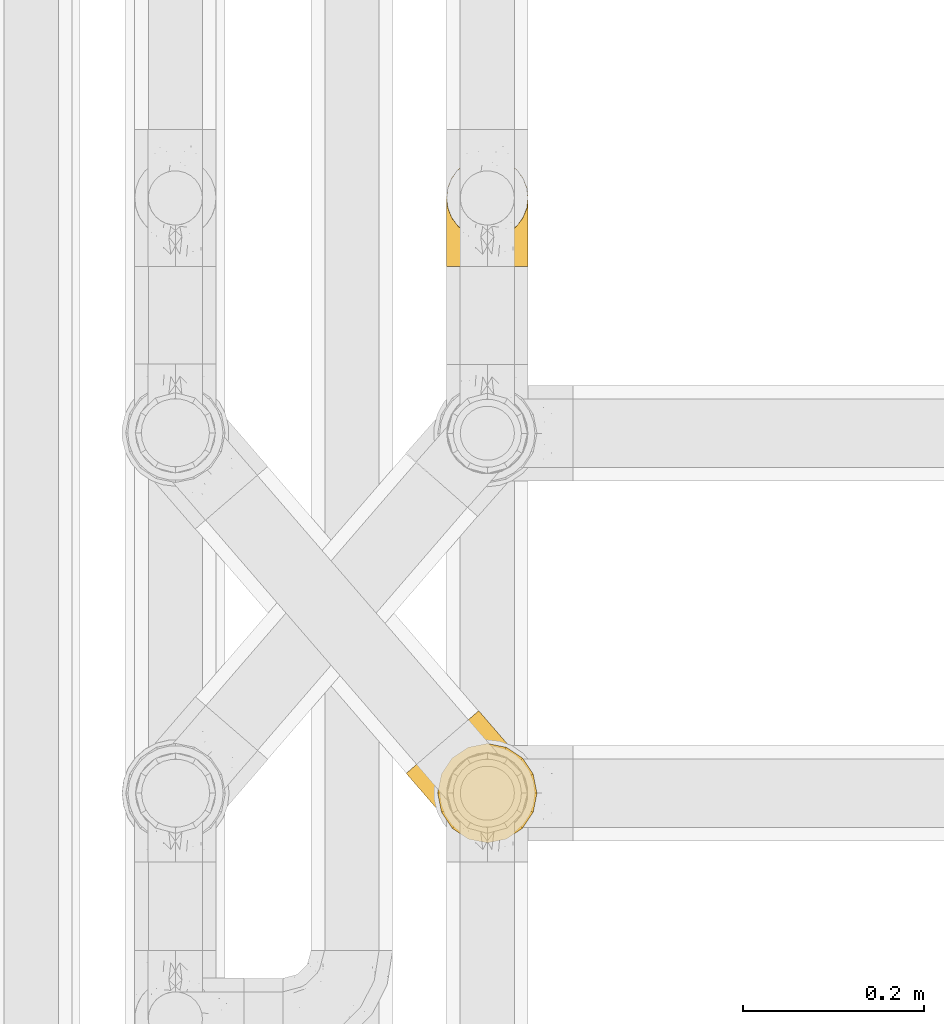
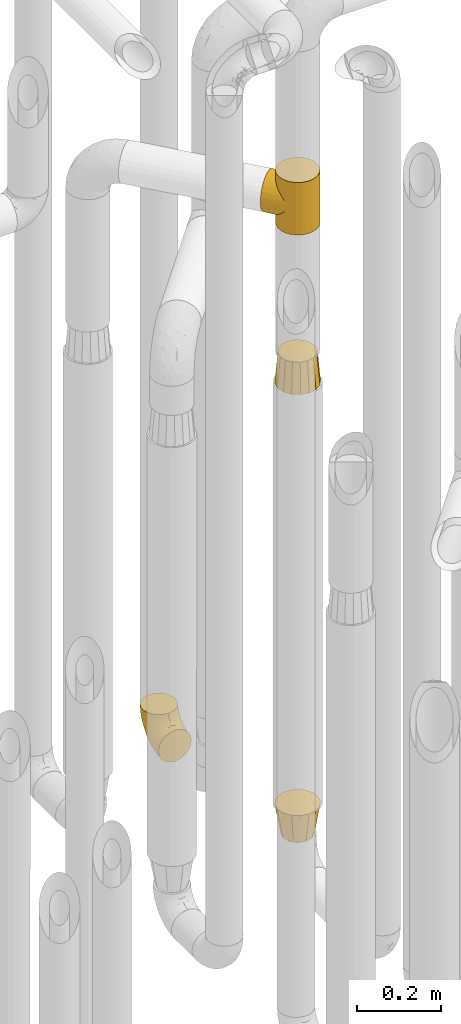
# One storey, part 230 of 827: 4 coverings.
"""IFC2X3 building model written with IfcOpenShell, lengths in millimetres."""

from ifc_helpers import new_model, entity, si_unit, converted_unit, derived_unit, direction, frame, origin, place, context, subcontext, project, spatial, faceted_brep, element, save


model = new_model("IFC2X3")

# Units and contexts
model_context = context("Model", 3, precision=0.01, world=origin(), true_north=direction((6.12303176911189e-17, 1.0)))
body_context = subcontext(model_context, "Body", "Model", "MODEL_VIEW")
ifc_project = project(units=[si_unit("LENGTHUNIT", "METRE", prefix="MILLI"), si_unit("AREAUNIT", "SQUARE_METRE"), si_unit("VOLUMEUNIT", "CUBIC_METRE"), converted_unit("PLANEANGLEUNIT", "DEGREE", entity("IfcRatioMeasure", 0.0174532925199433), si_unit("PLANEANGLEUNIT", "RADIAN"), dimensions=[0, 0, 0, 0, 0, 0, 0]), si_unit("MASSUNIT", "GRAM", prefix="KILO"), derived_unit("MASSDENSITYUNIT", [(si_unit("MASSUNIT", "GRAM", prefix="KILO"), 1), (si_unit("LENGTHUNIT", "METRE"), -3)]), derived_unit("MOMENTOFINERTIAUNIT", [(si_unit("LENGTHUNIT", "METRE"), 4)]), si_unit("TIMEUNIT", "SECOND"), si_unit("FREQUENCYUNIT", "HERTZ"), si_unit("THERMODYNAMICTEMPERATUREUNIT", "DEGREE_CELSIUS"), derived_unit("THERMALTRANSMITTANCEUNIT", [(si_unit("MASSUNIT", "GRAM", prefix="KILO"), 1), (si_unit("THERMODYNAMICTEMPERATUREUNIT", "KELVIN"), -1), (si_unit("TIMEUNIT", "SECOND"), -3)]), derived_unit("VOLUMETRICFLOWRATEUNIT", [(si_unit("LENGTHUNIT", "METRE"), 3), (si_unit("TIMEUNIT", "SECOND"), -1)]), derived_unit("MASSFLOWRATEUNIT", [(si_unit("MASSUNIT", "GRAM", prefix="KILO"), 1), (si_unit("TIMEUNIT", "SECOND"), -1)]), derived_unit("ROTATIONALFREQUENCYUNIT", [(si_unit("TIMEUNIT", "SECOND"), -1)]), si_unit("ELECTRICCURRENTUNIT", "AMPERE"), si_unit("ELECTRICVOLTAGEUNIT", "VOLT"), si_unit("POWERUNIT", "WATT"), si_unit("FORCEUNIT", "NEWTON", prefix="KILO"), si_unit("ILLUMINANCEUNIT", "LUX"), si_unit("LUMINOUSFLUXUNIT", "LUMEN"), si_unit("LUMINOUSINTENSITYUNIT", "CANDELA"), derived_unit("USERDEFINED", [(si_unit("MASSUNIT", "GRAM", prefix="KILO"), -1), (si_unit("LENGTHUNIT", "METRE"), -2), (si_unit("TIMEUNIT", "SECOND"), 3), (si_unit("LUMINOUSFLUXUNIT", "LUMEN"), 1)]), derived_unit("LINEARVELOCITYUNIT", [(si_unit("LENGTHUNIT", "METRE"), 1), (si_unit("TIMEUNIT", "SECOND"), -1)]), si_unit("PRESSUREUNIT", "PASCAL"), derived_unit("USERDEFINED", [(si_unit("LENGTHUNIT", "METRE"), -2), (si_unit("MASSUNIT", "GRAM", prefix="KILO"), 1), (si_unit("TIMEUNIT", "SECOND"), -2)]), derived_unit("LINEARFORCEUNIT", [(si_unit("MASSUNIT", "GRAM", prefix="KILO"), 1), (si_unit("LENGTHUNIT", "METRE"), 1), (si_unit("TIMEUNIT", "SECOND"), -2), (si_unit("LENGTHUNIT", "METRE"), -1)]), derived_unit("PLANARFORCEUNIT", [(si_unit("MASSUNIT", "GRAM", prefix="KILO"), 1), (si_unit("LENGTHUNIT", "METRE"), 1), (si_unit("TIMEUNIT", "SECOND"), -2), (si_unit("LENGTHUNIT", "METRE"), -2)])], contexts=[model_context])

# Site, building, storey
site_placement = place(None, origin())
site = spatial("IfcSite", under=ifc_project, at=site_placement, CompositionType="ELEMENT")
building_placement = place(site_placement, origin())
building = spatial("IfcBuilding", under=site, at=building_placement, CompositionType="ELEMENT")
storey_placement = place(building_placement, frame((0.0, 0.0, 28200.0)))
storey = spatial("IfcBuildingStorey", under=building, at=storey_placement, Name="08", CompositionType="ELEMENT", Elevation=28200.0)

# Coverings
covering_1_placement = place(storey_placement, frame((36883.62, 12525.7, 2274.0)))
element("IfcCovering", 1, at=covering_1_placement, inside=storey, Name=":ADSK_", ObjectType=":ADSK_", PredefinedType="INSULATION", context=body_context, shape_type="Brep", body=[
    faceted_brep([(126.54, 94.25, 68.86), (131.57, 89.16, 0.0), (121.24, 98.37, 0.0), (108.86, 104.6, 0.0), (114.42, 102.3, 54.84), (99.72, 106.9, 41.76), (95.3, 107.41, 0.0), (107.37, 105.09, 48.13), (131.57, 89.16, 76.0), (126.54, 94.25, 83.14), (131.57, 89.16, 152.0), (120.81, 98.66, 61.78), (91.49, 107.55, 35.89), (81.48, 106.61, 0.0), (73.82, 104.55, 26.62), (74.9, 104.44, 0.0), (68.33, 102.27, 0.0), (62.54, 98.47, 0.0), (56.75, 94.67, 0.0), (56.75, 94.67, 22.95), (62.54, 98.47, 152.0), (56.75, 94.67, 129.05), (56.75, 94.67, 152.0), (82.79, 106.85, 30.74), (64.96, 100.49, 23.9), (49.11, 86.52, 24.13), (49.11, 86.52, 127.87), (47.54, 84.33, 0.0), (43.53, 77.34, 27.43), (44.43, 78.14, 0.0), (41.31, 71.96, 0.0), (38.5, 58.4, 0.0), (38.51, 58.49, 38.42), (40.06, 67.84, 32.36), (38.59, 49.55, 45.24), (39.3, 44.57, 0.0), (40.07, 41.15, 52.57), (43.64, 31.42, 0.0), (46.51, 26.24, 68.06), (51.25, 19.84, 0.0), (42.75, 33.36, 60.22), (51.25, 19.84, 76.0), (46.51, 26.24, 83.94), (51.25, 19.84, 152.0), (114.49, 6.74, 152.0), (126.07, 14.34, 152.0), (135.28, 24.68, 152.0), (141.51, 37.05, 152.0), (144.32, 50.61, 152.0), (143.52, 64.43, 152.0), (139.18, 77.58, 152.0), (121.24, 98.37, 152.0), (108.86, 104.6, 152.0), (95.3, 107.41, 152.0), (81.48, 106.61, 152.0), (74.9, 104.44, 152.0), (68.33, 102.27, 152.0), (47.54, 84.33, 152.0), (44.43, 78.14, 152.0), (41.31, 71.96, 152.0), (38.5, 58.4, 152.0), (39.3, 44.57, 152.0), (43.64, 31.42, 152.0), (61.58, 10.63, 152.0), (73.96, 4.41, 152.0), (87.52, 1.6, 152.0), (101.34, 2.39, 152.0), (139.18, 77.58, 0.0), (143.52, 64.43, 0.0), (144.32, 50.61, 0.0), (141.51, 37.05, 0.0), (135.28, 24.68, 0.0), (126.07, 14.34, 0.0), (114.49, 6.74, 0.0), (101.34, 2.39, 0.0), (87.52, 1.6, 0.0), (73.96, 4.41, 0.0), (61.58, 10.63, 0.0), (120.81, 98.66, 90.22), (114.42, 102.3, 97.16), (107.37, 105.09, 103.87), (99.72, 106.9, 110.24), (91.49, 107.55, 116.11), (82.79, 106.85, 121.26), (73.82, 104.55, 125.38), (64.96, 100.49, 128.1), (43.53, 77.34, 124.57), (40.06, 67.84, 119.64), (38.51, 58.49, 113.58), (40.07, 41.15, 99.43), (42.75, 33.36, 91.78), (38.59, 49.55, 106.76), (81.92, 146.7, 76.0), (80.55, 145.52, 62.27), (76.54, 142.06, 49.47), (70.16, 136.55, 38.49), (61.84, 129.37, 30.06), (57.0, 125.19, 27.41), (52.15, 121.01, 24.76), (46.96, 116.53, 23.85), (41.76, 112.04, 22.95), (31.36, 103.07, 24.76), (26.52, 98.89, 27.41), (21.68, 94.71, 30.06), (13.36, 87.54, 38.49), (6.98, 82.03, 49.47), (2.96, 78.56, 62.27), (1.6, 77.38, 76.0), (2.96, 78.56, 89.73), (6.98, 82.03, 102.53), (13.36, 87.54, 113.51), (21.68, 94.71, 121.94), (26.52, 98.89, 124.59), (31.36, 103.07, 127.24), (41.76, 112.04, 129.05), (46.96, 116.53, 128.15), (52.15, 121.01, 127.24), (57.0, 125.19, 124.59), (61.84, 129.37, 121.94), (70.16, 136.55, 113.51), (76.54, 142.06, 102.53), (80.55, 145.52, 89.73)], [[[0, 1, 2]], [[2, 3, 4]], [[5, 3, 6]], [[5, 7, 3]], [[0, 8, 1]], [[8, 9, 10]], [[4, 11, 2]], [[7, 4, 3]], [[0, 2, 11]], [[12, 6, 13]], [[14, 13, 15, 16]], [[17, 18, 19]], [[20, 21, 22]], [[23, 12, 13]], [[24, 14, 16]], [[24, 17, 19]], [[24, 16, 17]], [[23, 13, 14]], [[6, 12, 5]], [[25, 19, 18]], [[21, 26, 22]], [[25, 18, 27]], [[28, 27, 29, 30]], [[28, 25, 27]], [[31, 32, 33]], [[28, 30, 33]], [[33, 30, 31]], [[34, 31, 35]], [[36, 35, 37]], [[38, 37, 39]], [[36, 34, 35]], [[38, 40, 37]], [[41, 38, 39]], [[42, 41, 43]], [[36, 37, 40]], [[31, 34, 32]], [[44, 45, 46, 47, 48, 49, 50, 10, 51, 52, 53, 54, 55, 56, 20, 22, 57, 58, 59, 60, 61, 62, 43, 63, 64, 65, 66]], [[1, 67, 68, 69, 70, 71, 72, 73, 74, 75, 76, 77, 39, 37, 35, 31, 30, 29, 27, 18, 17, 16, 15, 13, 6, 3, 2]], [[70, 69, 48, 47]], [[45, 72, 71, 46]], [[46, 71, 70, 47]], [[49, 68, 67, 50]], [[1, 8, 10, 50, 67]], [[48, 69, 68, 49]], [[78, 79, 51]], [[9, 78, 51]], [[10, 9, 51]], [[52, 80, 81]], [[52, 51, 79]], [[52, 81, 53]], [[80, 52, 79]], [[82, 83, 54]], [[84, 56, 55, 54]], [[84, 85, 56]], [[21, 20, 85]], [[83, 84, 54]], [[53, 82, 54]], [[85, 20, 56]], [[82, 53, 81]], [[26, 86, 57]], [[59, 87, 60]], [[86, 59, 58, 57]], [[86, 87, 59]], [[22, 26, 57]], [[87, 88, 60]], [[89, 90, 62]], [[90, 42, 62]], [[60, 91, 61]], [[91, 60, 88]], [[89, 61, 91]], [[89, 62, 61]], [[42, 43, 62]], [[41, 39, 77, 63, 43]], [[63, 77, 76, 64]], [[76, 75, 65, 64]], [[65, 75, 74, 66]], [[66, 74, 73, 44]], [[44, 73, 72, 45]], [[92, 93, 94, 95, 96, 97, 98, 99, 100, 101, 102, 103, 104, 105, 106, 107, 108, 109, 110, 111, 112, 113, 114, 115, 116, 117, 118, 119, 120, 121]], [[24, 99, 98]], [[96, 95, 12]], [[14, 98, 97, 96]], [[19, 99, 24]], [[19, 100, 99]], [[23, 14, 96]], [[12, 23, 96]], [[24, 98, 14]], [[95, 5, 12]], [[7, 5, 94]], [[94, 5, 95]], [[4, 94, 93]], [[0, 93, 92]], [[4, 7, 94]], [[0, 11, 93]], [[8, 0, 92]], [[4, 93, 11]], [[9, 92, 121]], [[121, 120, 79]], [[81, 120, 119]], [[81, 80, 120]], [[9, 8, 92]], [[79, 78, 121]], [[80, 79, 120]], [[9, 121, 78]], [[82, 119, 118]], [[84, 118, 117, 116]], [[115, 114, 21]], [[83, 82, 118]], [[85, 84, 116]], [[85, 115, 21]], [[85, 116, 115]], [[83, 118, 84]], [[119, 82, 81]], [[26, 21, 114]], [[26, 114, 113]], [[86, 113, 112, 111]], [[86, 26, 113]], [[110, 88, 87]], [[86, 111, 87]], [[87, 111, 110]], [[91, 110, 109]], [[89, 109, 108]], [[42, 108, 107]], [[89, 91, 109]], [[42, 90, 108]], [[41, 42, 107]], [[89, 108, 90]], [[110, 91, 88]], [[38, 107, 106]], [[106, 105, 36]], [[34, 105, 104]], [[34, 36, 105]], [[38, 41, 107]], [[36, 40, 106]], [[38, 106, 40]], [[33, 104, 103]], [[28, 103, 102, 101]], [[25, 101, 100]], [[33, 32, 104]], [[25, 28, 101]], [[19, 25, 100]], [[33, 103, 28]], [[104, 32, 34]]]),
])
covering_2_placement = place(storey_placement, frame((36918.44, 12524.58, 1811.0)))
element("IfcCovering", 2, at=covering_2_placement, inside=storey, Name=":ADSK_", ObjectType=":ADSK_", PredefinedType="INSULATION", context=body_context, shape_type="Brep", body=[
    faceted_brep([(35.55, 107.41, 0.0), (43.51, 108.99, 0.0), (56.6, 111.6, 0.0), (69.69, 108.99, 0.0), (77.64, 107.41, 0.0), (86.56, 101.45, 0.0), (95.49, 95.49, 0.0), (101.45, 86.56, 0.0), (107.41, 77.64, 0.0), (108.99, 69.69, 0.0), (111.6, 56.6, 0.0), (108.99, 43.51, 0.0), (107.41, 35.55, 0.0), (101.45, 26.63, 0.0), (95.49, 17.7, 0.0), (86.56, 11.74, 0.0), (77.64, 5.78, 0.0), (69.69, 4.2, 0.0), (56.6, 1.6, 0.0), (43.51, 4.2, 0.0), (35.55, 5.78, 0.0), (26.63, 11.74, 0.0), (17.7, 17.7, 0.0), (11.74, 26.63, 0.0), (5.78, 35.55, 0.0), (4.2, 43.51, 0.0), (1.6, 56.6, 0.0), (4.2, 69.69, 0.0), (5.78, 77.64, 0.0), (11.74, 86.56, 0.0), (17.7, 95.49, 0.0), (26.63, 101.45, 0.0), (9.1, 56.6, 89.0), (10.9, 47.51, 89.0), (12.71, 38.42, 89.0), (17.86, 30.71, 89.0), (23.01, 23.01, 89.0), (30.71, 17.86, 89.0), (38.42, 12.71, 89.0), (47.51, 10.9, 89.0), (56.6, 9.1, 89.0), (65.68, 10.9, 89.0), (74.77, 12.71, 89.0), (82.48, 17.86, 89.0), (90.18, 23.01, 89.0), (95.33, 30.71, 89.0), (100.48, 38.42, 89.0), (102.29, 47.51, 89.0), (104.1, 56.6, 89.0), (102.29, 65.68, 89.0), (100.48, 74.77, 89.0), (95.33, 82.48, 89.0), (90.18, 90.18, 89.0), (82.48, 95.33, 89.0), (74.77, 100.48, 89.0), (65.68, 102.29, 89.0), (56.6, 104.1, 89.0), (47.51, 102.29, 89.0), (38.42, 100.48, 89.0), (30.71, 95.33, 89.0), (23.01, 90.18, 89.0), (17.86, 82.48, 89.0), (12.71, 74.77, 89.0), (10.9, 65.68, 89.0)], [[[0, 1, 2, 3, 4, 5, 6, 7, 8, 9, 10, 11, 12, 13, 14, 15, 16, 17, 18, 19, 20, 21, 22, 23, 24, 25, 26, 27, 28, 29, 30, 31]], [[32, 33, 34, 35, 36, 37, 38, 39, 40, 41, 42, 43, 44, 45, 46, 47, 48, 49, 50, 51, 52, 53, 54, 55, 56, 57, 58, 59, 60, 61, 62, 63]], [[46, 12, 11, 10, 48, 47]], [[44, 14, 13, 12, 46, 45]], [[42, 16, 15, 14, 44, 43]], [[41, 40, 18, 17, 16, 42]], [[38, 20, 19, 18, 40, 39]], [[36, 22, 21, 20, 38, 37]], [[34, 24, 23, 22, 36, 35]], [[33, 32, 26, 25, 24, 34]], [[62, 28, 27, 26, 32, 63]], [[60, 30, 29, 28, 62, 61]], [[58, 0, 31, 30, 60, 59]], [[57, 56, 2, 1, 0, 58]], [[54, 4, 3, 2, 56, 55]], [[52, 6, 5, 4, 54, 53]], [[50, 8, 7, 6, 52, 51]], [[49, 48, 10, 9, 8, 50]]]),
])
covering_3_placement = place(storey_placement, frame((36918.44, 12524.58, 500.0)))
element("IfcCovering", 3, at=covering_3_placement, inside=storey, Name=":ADSK_", ObjectType=":ADSK_", PredefinedType="INSULATION", context=body_context, shape_type="Brep", body=[
    faceted_brep([(101.45, 86.56, 89.0), (95.49, 95.49, 89.0), (86.56, 101.45, 89.0), (77.64, 107.41, 89.0), (67.12, 109.5, 89.0), (56.6, 111.6, 89.0), (46.07, 109.5, 89.0), (35.55, 107.41, 89.0), (26.63, 101.45, 89.0), (17.7, 95.49, 89.0), (11.74, 86.56, 89.0), (5.78, 77.64, 89.0), (3.69, 67.12, 89.0), (1.6, 56.6, 89.0), (3.69, 46.07, 89.0), (5.78, 35.55, 89.0), (11.74, 26.63, 89.0), (17.7, 17.7, 89.0), (26.63, 11.74, 89.0), (35.55, 5.78, 89.0), (46.07, 3.69, 89.0), (56.6, 1.6, 89.0), (67.12, 3.69, 89.0), (77.64, 5.78, 89.0), (86.56, 11.74, 89.0), (95.49, 17.7, 89.0), (101.45, 26.63, 89.0), (107.41, 35.55, 89.0), (109.5, 46.07, 89.0), (111.6, 56.6, 89.0), (109.5, 67.12, 89.0), (107.41, 77.64, 89.0), (91.24, 36.6, 0.0), (83.92, 29.27, 0.0), (76.6, 21.95, 0.0), (66.6, 19.27, 0.0), (56.6, 16.6, 0.0), (46.6, 19.27, 0.0), (36.6, 21.95, 0.0), (29.27, 29.27, 0.0), (21.95, 36.6, 0.0), (19.27, 46.6, 0.0), (16.6, 56.6, 0.0), (19.27, 66.6, 0.0), (21.95, 76.6, 0.0), (29.27, 83.92, 0.0), (36.6, 91.24, 0.0), (46.6, 93.92, 0.0), (56.6, 96.6, 0.0), (66.6, 93.92, 0.0), (76.6, 91.24, 0.0), (83.92, 83.92, 0.0), (91.24, 76.6, 0.0), (93.92, 66.6, 0.0), (96.6, 56.6, 0.0), (93.92, 46.6, 0.0)], [[[0, 1, 2, 3, 4, 5, 6, 7, 8, 9, 10, 11, 12, 13, 14, 15, 16, 17, 18, 19, 20, 21, 22, 23, 24, 25, 26, 27, 28, 29, 30, 31]], [[32, 33, 34, 35, 36, 37, 38, 39, 40, 41, 42, 43, 44, 45, 46, 47, 48, 49, 50, 51, 52, 53, 54, 55]], [[6, 5, 48]], [[44, 10, 45]], [[45, 8, 46]], [[48, 47, 6]], [[9, 45, 10]], [[44, 11, 10]], [[8, 45, 9]], [[42, 12, 43]], [[8, 7, 46]], [[47, 46, 7]], [[12, 42, 13]], [[11, 44, 43]], [[12, 11, 43]], [[47, 7, 6]], [[14, 13, 42]], [[38, 18, 39]], [[39, 16, 40]], [[42, 41, 14]], [[17, 39, 18]], [[38, 19, 18]], [[16, 39, 17]], [[36, 20, 37]], [[16, 15, 40]], [[41, 40, 15]], [[20, 36, 21]], [[19, 38, 37]], [[20, 19, 37]], [[41, 15, 14]], [[22, 21, 36]], [[32, 26, 33]], [[33, 24, 34]], [[36, 35, 22]], [[25, 33, 26]], [[32, 27, 26]], [[24, 33, 25]], [[54, 28, 55]], [[24, 23, 34]], [[35, 34, 23]], [[28, 54, 29]], [[27, 32, 55]], [[28, 27, 55]], [[35, 23, 22]], [[30, 29, 54]], [[50, 2, 51]], [[51, 0, 52]], [[54, 53, 30]], [[1, 51, 2]], [[50, 3, 2]], [[0, 51, 1]], [[48, 4, 49]], [[0, 31, 52]], [[53, 52, 31]], [[4, 48, 5]], [[3, 50, 49]], [[4, 3, 49]], [[53, 31, 30]]]),
])
covering_4_placement = place(storey_placement, frame((36928.29, 13162.61, 353.25)))
element("IfcCovering", 4, at=covering_4_placement, inside=storey, Name=":ADSK_", ObjectType=":ADSK_", PredefinedType="INSULATION", context=body_context, shape_type="Brep", body=[
    faceted_brep([(2.73, 1.6, 36.69), (6.07, 1.6, 27.15), (11.45, 1.6, 18.59), (18.6, 1.6, 11.44), (27.16, 1.6, 6.06), (36.7, 1.6, 2.73), (46.75, 1.6, 1.6), (56.8, 1.6, 2.73), (66.34, 1.6, 6.07), (74.9, 1.6, 11.45), (82.05, 1.6, 18.6), (87.43, 1.6, 27.16), (90.76, 1.6, 36.7), (91.9, 1.6, 46.75), (90.76, 1.6, 56.8), (87.42, 1.6, 66.34), (82.04, 1.6, 74.9), (74.89, 1.6, 82.05), (66.33, 1.6, 87.43), (56.79, 1.6, 90.76), (46.75, 1.6, 91.9), (36.69, 1.6, 90.76), (27.15, 1.6, 87.42), (18.59, 1.6, 82.04), (11.44, 1.6, 74.89), (6.06, 1.6, 66.33), (2.73, 1.6, 56.79), (1.6, 1.6, 46.75), (58.43, 33.98, 122.75), (69.32, 38.49, 122.75), (78.67, 45.67, 122.75), (85.85, 55.02, 122.75), (90.36, 65.91, 122.75), (91.9, 77.6, 122.75), (90.36, 89.28, 122.75), (85.85, 100.17, 122.75), (78.67, 109.52, 122.75), (69.32, 116.7, 122.75), (58.43, 121.21, 122.75), (46.75, 122.75, 122.75), (35.06, 121.21, 122.75), (24.17, 116.7, 122.75), (14.82, 109.52, 122.75), (7.64, 100.17, 122.75), (3.13, 89.28, 122.75), (1.6, 77.6, 122.75), (3.13, 65.91, 122.75), (7.64, 55.02, 122.75), (14.82, 45.67, 122.75), (24.17, 38.49, 122.75), (35.06, 33.98, 122.75), (46.75, 32.45, 122.75), (46.75, 72.81, 24.73), (38.29, 77.17, 29.08), (46.75, 86.21, 38.13), (46.75, 116.82, 85.31), (38.96, 118.49, 93.59), (46.75, 119.23, 100.54), (33.86, 105.14, 63.54), (31.42, 85.37, 38.98), (21.63, 89.33, 50.71), (30.84, 116.14, 93.33), (22.16, 105.06, 75.2), (20.56, 112.15, 100.46), (2.29, 22.95, 41.6), (7.18, 89.91, 80.86), (12.6, 103.39, 94.87), (14.0, 93.6, 67.96), (2.81, 51.41, 52.16), (6.65, 67.71, 52.1), (6.11, 43.53, 36.74), (16.62, 30.91, 17.11), (9.76, 23.58, 23.24), (12.46, 50.07, 29.18), (1.6, 30.68, 52.53), (1.6, 43.01, 60.77), (1.6, 55.34, 69.01), (2.46, 83.48, 100.68), (5.91, 94.96, 103.79), (36.97, 57.29, 16.37), (46.75, 39.03, 7.52), (33.09, 30.66, 7.31), (1.6, 71.81, 93.66), (1.6, 73.63, 102.83), (1.6, 75.46, 112.01), (25.62, 51.57, 18.17), (3.14, 73.13, 71.97), (23.92, 23.16, 9.83), (46.75, 23.8, 5.11), (13.58, 75.6, 45.97), (1.6, 12.33, 48.88), (1.6, 21.51, 50.71), (18.5, 50.46, 22.83), (46.75, 99.61, 51.54), (1.6, 63.57, 81.33), (4.96, 21.26, 31.74), (20.84, 69.54, 32.48), (46.75, 108.21, 68.42), (30.52, 68.42, 25.33), (46.75, 55.92, 16.13), (27.29, 19.36, 92.29), (36.89, 15.76, 94.12), (33.6, 26.13, 100.97), (2.54, 62.78, 95.91), (3.27, 63.65, 107.9), (16.85, 24.34, 87.24), (21.91, 28.46, 95.46), (13.5, 33.53, 90.41), (3.96, 39.46, 74.17), (3.52, 51.05, 83.77), (12.17, 10.94, 76.72), (18.93, 14.55, 84.44), (9.34, 22.21, 76.42), (3.12, 57.05, 90.07), (5.67, 54.0, 99.69), (2.51, 29.19, 61.74), (2.53, 18.85, 58.16), (8.35, 52.84, 112.6), (35.39, 31.47, 110.45), (46.75, 28.31, 107.32), (15.1, 43.0, 108.48), (5.27, 16.9, 66.63), (27.43, 35.98, 115.23), (24.89, 33.91, 105.79), (29.71, 9.97, 89.6), (5.07, 25.93, 69.39), (2.88, 35.61, 66.99), (9.69, 47.45, 102.31), (15.51, 38.26, 99.54), (2.27, 11.7, 55.27), (10.03, 30.13, 82.03), (46.75, 12.12, 94.71), (46.75, 17.02, 96.03), (8.83, 44.39, 94.11), (7.16, 39.83, 84.21), (46.75, 22.67, 101.67), (46.75, 29.63, 112.22), (78.39, 43.0, 108.48), (83.8, 47.45, 102.31), (77.97, 38.26, 99.54), (84.66, 44.38, 94.11), (58.1, 31.47, 110.46), (81.31, 10.93, 76.74), (91.9, 21.51, 50.71), (90.96, 18.84, 58.17), (91.22, 11.7, 55.27), (56.59, 15.76, 94.12), (66.18, 19.36, 92.3), (59.87, 26.14, 100.98), (88.42, 25.94, 69.41), (84.13, 22.21, 76.44), (88.22, 16.9, 66.65), (66.06, 35.98, 115.24), (91.9, 73.63, 102.83), (91.9, 75.46, 112.01), (83.44, 30.12, 82.05), (76.62, 24.33, 87.25), (85.14, 52.84, 112.6), (90.22, 63.65, 107.9), (91.9, 71.81, 93.66), (71.55, 28.45, 95.48), (63.77, 9.97, 89.6), (91.9, 43.01, 60.77), (91.9, 55.34, 69.01), (89.53, 39.46, 74.17), (91.9, 12.33, 48.88), (74.55, 14.54, 84.45), (90.95, 62.78, 95.91), (90.37, 57.05, 90.07), (91.9, 63.57, 81.33), (90.98, 29.2, 61.75), (89.97, 51.05, 83.77), (86.32, 39.81, 84.21), (91.9, 30.68, 52.53), (79.97, 33.52, 90.42), (90.61, 35.61, 67.0), (87.82, 54.0, 99.69), (68.6, 33.91, 105.8), (80.89, 103.39, 94.87), (86.31, 89.91, 80.86), (79.49, 93.6, 67.95), (71.33, 105.05, 75.17), (71.88, 89.27, 50.65), (90.35, 73.13, 71.97), (86.85, 67.67, 52.08), (72.67, 69.49, 32.46), (62.08, 85.36, 38.98), (87.58, 94.96, 103.79), (91.03, 83.48, 100.68), (59.62, 105.14, 63.54), (62.65, 116.13, 93.32), (54.53, 118.49, 93.59), (72.93, 112.15, 100.44), (90.68, 51.41, 52.17), (87.39, 43.51, 36.75), (91.2, 22.95, 41.61), (60.41, 30.66, 7.31), (76.88, 30.91, 17.12), (56.53, 57.3, 16.37), (83.74, 23.58, 23.26), (67.88, 51.56, 18.17), (62.99, 68.41, 25.33), (69.58, 23.16, 9.84), (81.04, 50.07, 29.19), (75.0, 50.45, 22.84), (88.53, 21.25, 31.75), (79.93, 75.56, 45.96), (55.21, 77.16, 29.07)], [[[0, 1, 2, 3, 4, 5, 6, 7, 8, 9, 10, 11, 12, 13, 14, 15, 16, 17, 18, 19, 20, 21, 22, 23, 24, 25, 26, 27]], [[28, 29, 30, 31, 32, 33, 34, 35, 36, 37, 38, 39, 40, 41, 42, 43, 44, 45, 46, 47, 48, 49, 50, 51]], [[52, 53, 54]], [[55, 56, 57]], [[58, 59, 60]], [[61, 62, 63]], [[27, 64, 0]], [[65, 66, 67]], [[41, 40, 61]], [[68, 69, 70]], [[66, 43, 42]], [[63, 42, 41]], [[71, 72, 73]], [[72, 2, 1]], [[68, 74, 75, 76]], [[45, 44, 77]], [[43, 78, 44]], [[79, 80, 81]], [[77, 82, 83, 84, 45]], [[79, 81, 85]], [[71, 2, 72]], [[65, 86, 77]], [[4, 81, 5]], [[66, 65, 78]], [[4, 3, 87]], [[81, 88, 5]], [[63, 66, 42]], [[68, 70, 64]], [[67, 60, 89]], [[71, 3, 2]], [[64, 27, 90, 91, 74]], [[92, 71, 73]], [[40, 57, 56]], [[59, 93, 54]], [[86, 76, 94, 82]], [[1, 0, 95]], [[58, 62, 61]], [[60, 96, 89]], [[85, 81, 87]], [[56, 97, 58]], [[65, 67, 69]], [[87, 81, 4]], [[67, 89, 69]], [[61, 63, 41]], [[95, 72, 1]], [[73, 72, 70]], [[69, 73, 70]], [[73, 89, 96]], [[3, 71, 87]], [[85, 87, 71]], [[58, 61, 56]], [[59, 58, 93]], [[76, 86, 68]], [[69, 89, 73]], [[68, 86, 69]], [[65, 69, 86]], [[68, 64, 74]], [[95, 64, 70]], [[98, 79, 85]], [[79, 52, 99, 80]], [[66, 62, 67]], [[62, 58, 60]], [[62, 60, 67]], [[59, 98, 96]], [[59, 96, 60]], [[96, 85, 92]], [[88, 81, 80]], [[88, 6, 5]], [[66, 63, 62]], [[64, 95, 0]], [[72, 95, 70]], [[77, 44, 78]], [[86, 82, 77]], [[40, 39, 57]], [[96, 98, 85]], [[40, 56, 61]], [[66, 78, 43]], [[77, 78, 65]], [[79, 98, 53]], [[96, 92, 73]], [[85, 71, 92]], [[97, 56, 55]], [[97, 93, 58]], [[53, 98, 59]], [[54, 53, 59]], [[79, 53, 52]], [[100, 101, 102]], [[46, 45, 84, 83]], [[103, 104, 82]], [[82, 104, 83]], [[105, 106, 107]], [[108, 109, 76]], [[110, 111, 112]], [[103, 113, 114]], [[115, 74, 116]], [[48, 47, 117]], [[118, 102, 119]], [[49, 48, 120]], [[74, 91, 116]], [[116, 121, 115]], [[49, 122, 50]], [[123, 106, 102]], [[124, 111, 22]], [[125, 126, 115]], [[23, 22, 111]], [[24, 110, 121]], [[120, 127, 128]], [[90, 26, 129]], [[27, 26, 90]], [[121, 125, 115]], [[24, 121, 25]], [[130, 105, 107]], [[129, 25, 116]], [[21, 20, 131]], [[120, 123, 122]], [[112, 105, 130]], [[50, 118, 51]], [[21, 124, 22]], [[101, 131, 132]], [[117, 120, 48]], [[24, 23, 110]], [[127, 114, 133]], [[75, 108, 76]], [[107, 134, 130]], [[133, 114, 113]], [[129, 116, 91]], [[25, 121, 116]], [[121, 112, 125]], [[75, 74, 115]], [[101, 135, 102]], [[131, 101, 21]], [[101, 100, 124]], [[128, 127, 133]], [[119, 136, 51, 118]], [[104, 47, 46]], [[83, 104, 46]], [[117, 104, 114]], [[101, 124, 21]], [[111, 124, 100]], [[102, 118, 123]], [[133, 134, 107]], [[111, 110, 23]], [[114, 104, 103]], [[94, 76, 109]], [[121, 110, 112]], [[122, 118, 50]], [[134, 109, 108]], [[133, 107, 128]], [[112, 108, 125]], [[126, 125, 108]], [[108, 75, 126]], [[75, 115, 126]], [[109, 134, 133]], [[130, 108, 112]], [[108, 130, 134]], [[105, 112, 111]], [[111, 100, 105]], [[106, 105, 100]], [[102, 106, 100]], [[128, 106, 123]], [[90, 129, 91]], [[25, 129, 26]], [[104, 117, 47]], [[117, 114, 127]], [[82, 94, 103]], [[113, 94, 109]], [[94, 113, 103]], [[133, 113, 109]], [[106, 128, 107]], [[123, 120, 128]], [[120, 122, 49]], [[118, 122, 123]], [[135, 101, 132]], [[135, 119, 102]], [[117, 127, 120]], [[30, 29, 137]], [[138, 139, 140]], [[51, 136, 119, 141]], [[142, 17, 16]], [[143, 144, 145]], [[146, 147, 148]], [[149, 150, 151]], [[152, 29, 28]], [[33, 32, 153, 154]], [[150, 155, 156]], [[157, 31, 30]], [[153, 158, 159]], [[29, 152, 137]], [[148, 141, 119]], [[156, 160, 147]], [[148, 135, 146]], [[137, 138, 157]], [[19, 161, 146]], [[162, 163, 164]], [[14, 13, 165]], [[153, 32, 158]], [[147, 161, 166]], [[18, 17, 166]], [[167, 168, 169]], [[166, 150, 156]], [[151, 150, 142]], [[151, 170, 149]], [[151, 16, 15]], [[171, 140, 172]], [[165, 143, 145]], [[173, 170, 144]], [[142, 166, 17]], [[19, 131, 20]], [[144, 170, 151]], [[18, 161, 19]], [[173, 144, 143]], [[140, 139, 174]], [[171, 164, 163]], [[164, 172, 155]], [[151, 15, 144]], [[145, 15, 14]], [[173, 162, 170]], [[149, 175, 164]], [[19, 146, 131]], [[132, 131, 146]], [[160, 148, 147]], [[159, 158, 167]], [[135, 132, 146]], [[158, 32, 31]], [[157, 158, 31]], [[167, 158, 176]], [[166, 161, 18]], [[146, 161, 147]], [[148, 177, 141]], [[171, 168, 140]], [[171, 163, 169]], [[151, 142, 16]], [[166, 142, 150]], [[152, 141, 177]], [[51, 141, 28]], [[138, 140, 176]], [[172, 140, 174]], [[175, 149, 170]], [[164, 150, 149]], [[170, 162, 175]], [[162, 164, 175]], [[155, 172, 174]], [[171, 172, 164]], [[155, 174, 156]], [[164, 155, 150]], [[160, 156, 174]], [[147, 166, 156]], [[139, 160, 174]], [[148, 160, 177]], [[15, 145, 144]], [[165, 145, 14]], [[137, 157, 30]], [[158, 157, 176]], [[168, 167, 176]], [[169, 159, 167]], [[140, 168, 176]], [[169, 168, 171]], [[137, 177, 139]], [[160, 139, 177]], [[141, 152, 28]], [[137, 152, 177]], [[148, 119, 135]], [[157, 138, 176]], [[139, 138, 137]], [[178, 179, 180]], [[181, 180, 182]], [[179, 183, 184]], [[185, 186, 182]], [[187, 188, 179]], [[188, 33, 154, 153, 159]], [[181, 189, 190]], [[35, 34, 187]], [[191, 38, 190]], [[192, 178, 181]], [[179, 184, 180]], [[192, 190, 37]], [[37, 190, 38]], [[36, 35, 178]], [[54, 93, 186]], [[35, 187, 178]], [[193, 194, 184]], [[195, 173, 143, 165, 13]], [[195, 193, 173]], [[193, 163, 162, 173]], [[13, 12, 195]], [[8, 7, 196]], [[9, 197, 10]], [[198, 80, 99, 52]], [[196, 7, 88]], [[197, 199, 10]], [[182, 189, 181]], [[200, 198, 201]], [[200, 196, 198]], [[9, 8, 202]], [[194, 199, 203]], [[192, 37, 36]], [[80, 196, 88]], [[183, 159, 169, 163]], [[188, 34, 33]], [[202, 200, 197]], [[185, 203, 204]], [[202, 8, 196]], [[10, 199, 11]], [[12, 11, 205]], [[38, 191, 57]], [[189, 97, 191]], [[203, 199, 197]], [[205, 199, 194]], [[204, 203, 197]], [[184, 203, 206]], [[200, 202, 196]], [[197, 9, 202]], [[207, 54, 186]], [[97, 55, 191]], [[194, 203, 184]], [[183, 163, 193]], [[184, 206, 180]], [[183, 193, 184]], [[205, 195, 12]], [[193, 195, 194]], [[80, 198, 196]], [[207, 186, 201]], [[182, 180, 206]], [[181, 178, 180]], [[185, 182, 206]], [[182, 186, 189]], [[203, 185, 206]], [[185, 200, 201]], [[7, 6, 88]], [[178, 192, 36]], [[190, 192, 181]], [[199, 205, 11]], [[195, 205, 194]], [[159, 183, 188]], [[179, 188, 183]], [[57, 191, 55]], [[57, 39, 38]], [[189, 191, 190]], [[188, 187, 34]], [[178, 187, 179]], [[186, 93, 189]], [[197, 200, 204]], [[185, 204, 200]], [[189, 93, 97]], [[207, 198, 52]], [[185, 201, 186]], [[198, 207, 201]], [[54, 207, 52]]]),
])

save(model, "model.ifc")
